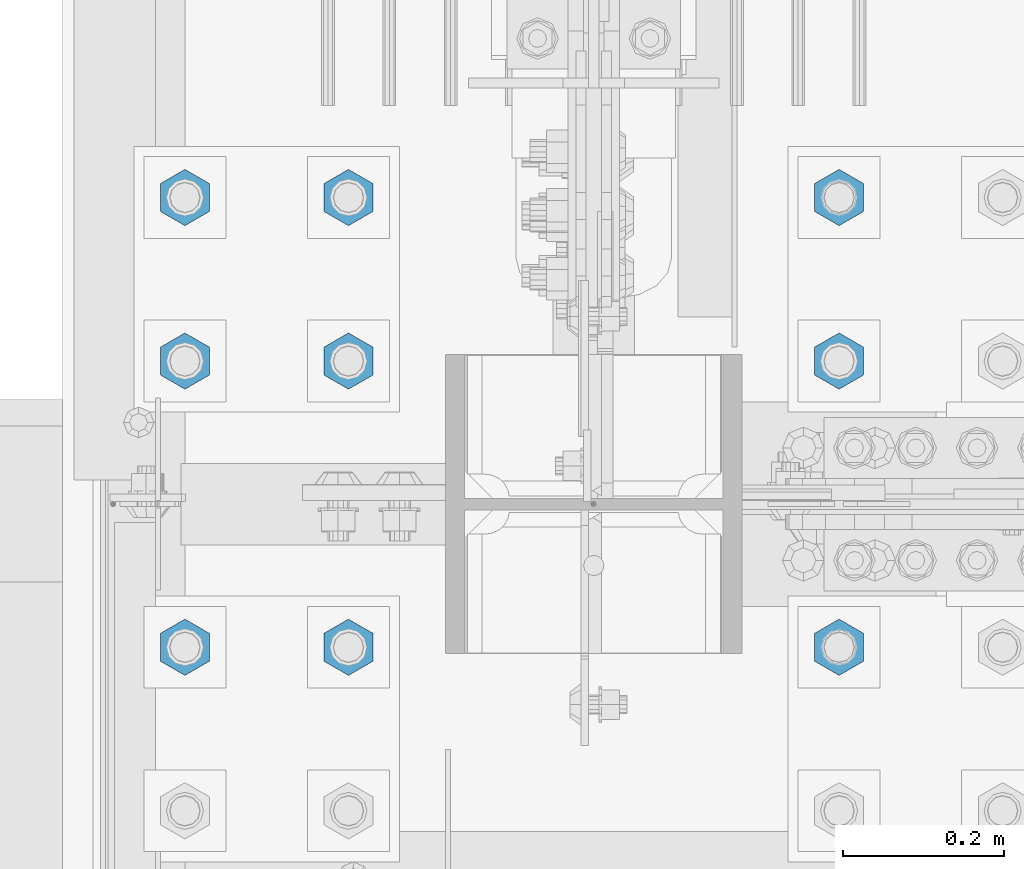
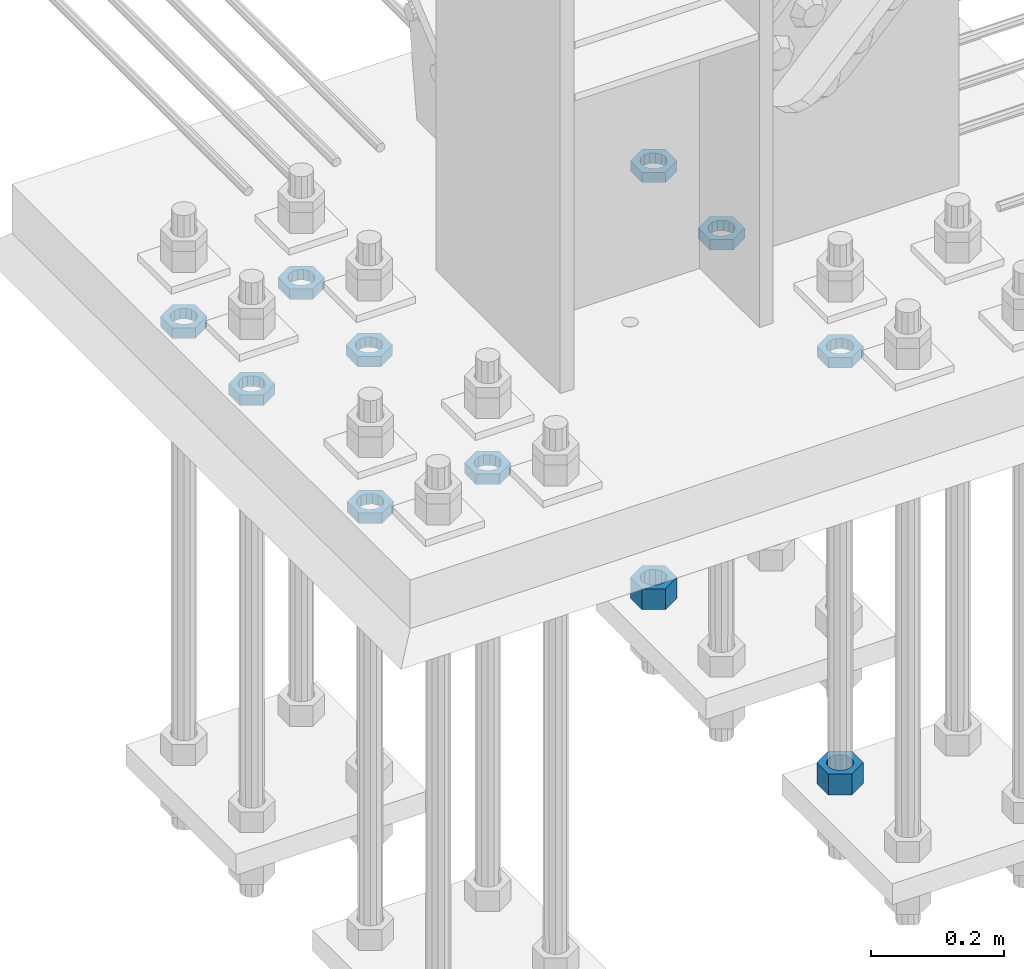
# One storey, part 2803 of 3843: 11 beams, 1 element without a shape of its own.
"""IFC2X3 building model written with IfcOpenShell, lengths in millimetres."""

from ifc_helpers import new_model, si_unit, frame, origin_with_axes, place, context, subcontext, project, spatial, faceted_brep, material, type_object, element, aggregate, save


model = new_model("IFC2X3")

# Units and contexts
model_context = context("Model", 3, precision=1e-05, world=origin_with_axes())
body_context = subcontext(model_context, "Body", "Model", "MODEL_VIEW")
ifc_project = project(units=[si_unit("LENGTHUNIT", "METRE", prefix="MILLI"), si_unit("AREAUNIT", "SQUARE_METRE"), si_unit("VOLUMEUNIT", "CUBIC_METRE"), si_unit("MASSUNIT", "GRAM", prefix="KILO"), si_unit("TIMEUNIT", "SECOND"), si_unit("PLANEANGLEUNIT", "RADIAN"), si_unit("SOLIDANGLEUNIT", "STERADIAN"), si_unit("THERMODYNAMICTEMPERATUREUNIT", "DEGREE_CELSIUS"), si_unit("LUMINOUSINTENSITYUNIT", "LUMEN")], contexts=[model_context])

# Site, building, storey
site_placement = place(None, origin_with_axes())
site = spatial("IfcSite", under=ifc_project, at=site_placement, CompositionType="ELEMENT")
building_placement = place(site_placement, origin_with_axes())
building = spatial("IfcBuilding", under=site, at=building_placement, Name="Undefined", CompositionType="ELEMENT")
storey_placement = place(building_placement, origin_with_axes())
storey = spatial("IfcBuildingStorey", under=building, at=storey_placement, Name="Undefined", CompositionType="ELEMENT", Elevation=0.0)

# Assembly, beams
assembly_placement = place(storey_placement, origin_with_axes())
assembly = element("IfcElementAssembly", 1, at=assembly_placement, inside=storey, Name="TEMPLATE", AssemblyPlace="NOTDEFINED", PredefinedType="RIGID_FRAME")
ifc_material = material(Name="STEEL/A572-50")
beam_type_1 = type_object("IfcBeamType", Name="1-1/2_HEAVY_HEX_NUT", PredefinedType="NOTDEFINED")
beam_1_placement = place(assembly_placement, frame((77317.599987793, 15379.6999969482, 29298.9000015259), z_axis=(1.0, 0.0, 0.0), x_axis=(0.0, 0.0, -1.0)))
beam_1 = element("IfcBeam", 2, at=beam_1_placement, type_object=beam_type_1, material=ifc_material, Name="NUT", ObjectType="1-1/2_HEAVY_HEX_NUT", context=body_context, shape_type="Brep", body=[
    faceted_brep([(0.0, -34.9199981689453, 0.0), (0.0, -17.4599990844727, -30.25), (38.0999999999985, -17.4599990844727, -30.25), (38.0999999999985, -34.9199981689453, 0.0), (0.0, 17.4599990844727, -30.25), (38.0999999999985, 17.4599990844727, -30.25), (0.0, 34.9199981689453, 0.0), (38.0999999999985, 34.9199981689453, 0.0), (0.0, 17.4599990844727, 30.25), (38.0999999999985, 17.4599990844727, 30.25), (0.0, -17.4599990844727, 30.25), (38.0999999999985, -17.4599990844727, 30.25), (0.0, 0.0, 20.6399993896484), (0.0, 8.9553601105581, 18.5959968835959), (38.0999999999985, 8.9553601105581, 18.5959968835959), (38.0999999999985, 0.0, 20.6399993896484), (0.0, 16.1370013209525, 12.8688291298167), (38.0999999999985, 16.1370013209525, 12.8688291298167), (0.0, 20.1225115123816, 4.59283194104501), (38.0999999999985, 20.1225115123816, 4.59283194104501), (0.0, 20.1225115123816, -4.59283194104501), (38.0999999999985, 20.1225115123816, -4.59283194104501), (0.0, 16.1370013209525, -12.8688291298167), (38.0999999999985, 16.1370013209525, -12.8688291298167), (0.0, 8.9553601105581, -18.5959968835959), (38.0999999999985, 8.9553601105581, -18.5959968835959), (0.0, 0.0, -20.6399993896484), (38.0999999999985, 0.0, -20.6399993896484), (0.0, -8.9553601105581, -18.5959968835959), (38.0999999999985, -8.9553601105581, -18.5959968835959), (0.0, -16.1370013209525, -12.8688291298167), (38.0999999999985, -16.1370013209525, -12.8688291298167), (0.0, -20.1225115123816, -4.59283194104501), (38.0999999999985, -20.1225115123816, -4.59283194104501), (0.0, -20.1225115123816, 4.59283194104501), (38.0999999999985, -20.1225115123816, 4.59283194104501), (0.0, -16.1370013209525, 12.8688291298167), (38.0999999999985, -16.1370013209525, 12.8688291298167), (0.0, -8.9553601105581, 18.5959968835959), (38.0999999999985, -8.9553601105581, 18.5959968835959)], [[[0, 1, 2, 3]], [[1, 4, 5, 2]], [[4, 6, 7, 5]], [[6, 8, 9, 7]], [[8, 10, 11, 9]], [[10, 0, 3, 11]], [[12, 13, 14, 15]], [[13, 16, 17, 14]], [[16, 18, 19, 17]], [[18, 20, 21, 19]], [[20, 22, 23, 21]], [[22, 24, 25, 23]], [[24, 26, 27, 25]], [[26, 28, 29, 27]], [[28, 30, 31, 29]], [[30, 32, 33, 31]], [[32, 34, 35, 33]], [[34, 36, 37, 35]], [[36, 38, 39, 37]], [[38, 12, 15, 39]], [[5, 7, 9, 11, 3, 2], [17, 19, 21, 23, 25, 27, 29, 31, 33, 35, 37, 39, 15, 14]], [[10, 8, 6, 4, 1, 0], [38, 36, 34, 32, 30, 28, 26, 24, 22, 20, 18, 16, 13, 12]]]),
])
beam_2_placement = place(assembly_placement, frame((77317.599987793, 14820.8999969482, 29298.9000015259), z_axis=(1.0, 0.0, 0.0), x_axis=(0.0, 0.0, -1.0)))
beam_2 = element("IfcBeam", 3, at=beam_2_placement, type_object=beam_type_1, material=ifc_material, Name="NUT", ObjectType="1-1/2_HEAVY_HEX_NUT", context=body_context, shape_type="Brep", body=[
    faceted_brep([(0.0, -34.9199981689453, 0.0), (0.0, -17.4599990844727, -30.25), (38.0999999999985, -17.4599990844727, -30.25), (38.0999999999985, -34.9199981689453, 0.0), (0.0, 17.4599990844727, -30.25), (38.0999999999985, 17.4599990844727, -30.25), (0.0, 34.9199981689453, 0.0), (38.0999999999985, 34.9199981689453, 0.0), (0.0, 17.4599990844727, 30.25), (38.0999999999985, 17.4599990844727, 30.25), (0.0, -17.4599990844727, 30.25), (38.0999999999985, -17.4599990844727, 30.25), (0.0, 0.0, 20.6399993896484), (0.0, 8.9553601105581, 18.5959968835959), (38.0999999999985, 8.9553601105581, 18.5959968835959), (38.0999999999985, 0.0, 20.6399993896484), (0.0, 16.1370013209525, 12.8688291298167), (38.0999999999985, 16.1370013209525, 12.8688291298167), (0.0, 20.1225115123816, 4.59283194104501), (38.0999999999985, 20.1225115123816, 4.59283194104501), (0.0, 20.1225115123816, -4.59283194104501), (38.0999999999985, 20.1225115123816, -4.59283194104501), (0.0, 16.1370013209525, -12.8688291298167), (38.0999999999985, 16.1370013209525, -12.8688291298167), (0.0, 8.9553601105581, -18.5959968835959), (38.0999999999985, 8.9553601105581, -18.5959968835959), (0.0, 0.0, -20.6399993896484), (38.0999999999985, 0.0, -20.6399993896484), (0.0, -8.9553601105581, -18.5959968835959), (38.0999999999985, -8.9553601105581, -18.5959968835959), (0.0, -16.1370013209525, -12.8688291298167), (38.0999999999985, -16.1370013209525, -12.8688291298167), (0.0, -20.1225115123816, -4.59283194104501), (38.0999999999985, -20.1225115123816, -4.59283194104501), (0.0, -20.1225115123816, 4.59283194104501), (38.0999999999985, -20.1225115123816, 4.59283194104501), (0.0, -16.1370013209525, 12.8688291298167), (38.0999999999985, -16.1370013209525, 12.8688291298167), (0.0, -8.9553601105581, 18.5959968835959), (38.0999999999985, -8.9553601105581, 18.5959968835959)], [[[0, 1, 2, 3]], [[1, 4, 5, 2]], [[4, 6, 7, 5]], [[6, 8, 9, 7]], [[8, 10, 11, 9]], [[10, 0, 3, 11]], [[12, 13, 14, 15]], [[13, 16, 17, 14]], [[16, 18, 19, 17]], [[18, 20, 21, 19]], [[20, 22, 23, 21]], [[22, 24, 25, 23]], [[24, 26, 27, 25]], [[26, 28, 29, 27]], [[28, 30, 31, 29]], [[30, 32, 33, 31]], [[32, 34, 35, 33]], [[34, 36, 37, 35]], [[36, 38, 39, 37]], [[38, 12, 15, 39]], [[5, 7, 9, 11, 3, 2], [17, 19, 21, 23, 25, 27, 29, 31, 33, 35, 37, 39, 15, 14]], [[10, 8, 6, 4, 1, 0], [38, 36, 34, 32, 30, 28, 26, 24, 22, 20, 18, 16, 13, 12]]]),
])
beam_type_2 = type_object("IfcBeamType", Name="1-1/2_HALF_NUT", PredefinedType="NOTDEFINED")
beam_3_placement = place(assembly_placement, frame((77317.600012207, 15176.5000030518, 30060.9), z_axis=(-1.0, 0.0, 0.0), x_axis=(0.0, 0.0, -1.0)))
beam_3 = element("IfcBeam", 4, at=beam_3_placement, type_object=beam_type_2, material=ifc_material, Name="NUT", ObjectType="1-1/2_HALF_NUT", context=body_context, shape_type="Brep", body=[
    faceted_brep([(0.0, -34.9199981689453, 0.0), (0.0, -17.4599990844727, -30.25), (19.0500000000029, -17.4599990844727, -30.25), (19.0500000000029, -34.9199981689453, 0.0), (0.0, 17.4599990844727, -30.25), (19.0500000000029, 17.4599990844727, -30.25), (0.0, 34.9199981689453, 0.0), (19.0500000000029, 34.9199981689453, 0.0), (0.0, 17.4599990844727, 30.25), (19.0500000000029, 17.4599990844727, 30.25), (0.0, -17.4599990844727, 30.25), (19.0500000000029, -17.4599990844727, 30.25), (0.0, 0.0, 20.6399993896484), (0.0, 8.9553601105581, 18.5959968835959), (19.0500000000029, 8.95536011056538, 18.5959968835959), (19.0500000000029, 0.0, 20.6399993896484), (0.0, 16.1370013209525, 12.8688291298167), (19.0500000000029, 16.1370013209489, 12.8688291298167), (0.0, 20.1225115123816, 4.59283194104501), (19.0500000000029, 20.1225115123852, 4.59283194104501), (0.0, 20.1225115123816, -4.59283194104501), (19.0500000000029, 20.1225115123852, -4.59283194104501), (0.0, 16.1370013209525, -12.8688291298167), (19.0500000000029, 16.1370013209489, -12.8688291298167), (0.0, 8.9553601105581, -18.5959968835959), (19.0500000000029, 8.95536011056538, -18.5959968835959), (0.0, 0.0, -20.6399993896484), (19.0500000000029, 0.0, -20.6399993896484), (0.0, -8.9553601105581, -18.5959968835959), (19.0500000000029, -8.95536011056538, -18.5959968835959), (0.0, -16.1370013209525, -12.8688291298167), (19.0500000000029, -16.1370013209489, -12.8688291298167), (0.0, -20.1225115123816, -4.59283194104501), (19.0500000000029, -20.1225115123852, -4.59283194104501), (0.0, -20.1225115123816, 4.59283194104501), (19.0500000000029, -20.1225115123852, 4.59283194104501), (0.0, -16.1370013209525, 12.8688291298167), (19.0500000000029, -16.1370013209489, 12.8688291298167), (0.0, -8.9553601105581, 18.5959968835959), (19.0500000000029, -8.95536011056538, 18.5959968835959)], [[[0, 1, 2, 3]], [[1, 4, 5, 2]], [[4, 6, 7, 5]], [[6, 8, 9, 7]], [[8, 10, 11, 9]], [[10, 0, 3, 11]], [[12, 13, 14, 15]], [[13, 16, 17, 14]], [[16, 18, 19, 17]], [[18, 20, 21, 19]], [[20, 22, 23, 21]], [[22, 24, 25, 23]], [[24, 26, 27, 25]], [[26, 28, 29, 27]], [[28, 30, 31, 29]], [[30, 32, 33, 31]], [[32, 34, 35, 33]], [[34, 36, 37, 35]], [[36, 38, 39, 37]], [[38, 12, 15, 39]], [[5, 7, 9, 11, 3, 2], [17, 19, 21, 23, 25, 27, 29, 31, 33, 35, 37, 39, 15, 14]], [[10, 8, 6, 4, 1, 0], [38, 36, 34, 32, 30, 28, 26, 24, 22, 20, 18, 16, 13, 12]]]),
])
beam_4_placement = place(assembly_placement, frame((77317.600012207, 15379.7000030518, 30060.9), z_axis=(-1.0, 0.0, 0.0), x_axis=(0.0, 0.0, -1.0)))
beam_4 = element("IfcBeam", 5, at=beam_4_placement, type_object=beam_type_2, material=ifc_material, Name="NUT", ObjectType="1-1/2_HALF_NUT", context=body_context, shape_type="Brep", body=[
    faceted_brep([(0.0, -34.9199981689453, 0.0), (0.0, -17.4599990844727, -30.25), (19.0500000000029, -17.4599990844727, -30.25), (19.0500000000029, -34.9199981689453, 0.0), (0.0, 17.4599990844727, -30.25), (19.0500000000029, 17.4599990844727, -30.25), (0.0, 34.9199981689453, 0.0), (19.0500000000029, 34.9199981689453, 0.0), (0.0, 17.4599990844727, 30.25), (19.0500000000029, 17.4599990844727, 30.25), (0.0, -17.4599990844727, 30.25), (19.0500000000029, -17.4599990844727, 30.25), (0.0, 0.0, 20.6399993896484), (0.0, 8.9553601105581, 18.5959968835959), (19.0500000000029, 8.95536011056538, 18.5959968835959), (19.0500000000029, 0.0, 20.6399993896484), (0.0, 16.1370013209525, 12.8688291298167), (19.0500000000029, 16.1370013209489, 12.8688291298167), (0.0, 20.1225115123816, 4.59283194104501), (19.0500000000029, 20.1225115123852, 4.59283194104501), (0.0, 20.1225115123816, -4.59283194104501), (19.0500000000029, 20.1225115123852, -4.59283194104501), (0.0, 16.1370013209525, -12.8688291298167), (19.0500000000029, 16.1370013209489, -12.8688291298167), (0.0, 8.9553601105581, -18.5959968835959), (19.0500000000029, 8.95536011056538, -18.5959968835959), (0.0, 0.0, -20.6399993896484), (19.0500000000029, 0.0, -20.6399993896484), (0.0, -8.9553601105581, -18.5959968835959), (19.0500000000029, -8.95536011056538, -18.5959968835959), (0.0, -16.1370013209525, -12.8688291298167), (19.0500000000029, -16.1370013209489, -12.8688291298167), (0.0, -20.1225115123816, -4.59283194104501), (19.0500000000029, -20.1225115123852, -4.59283194104501), (0.0, -20.1225115123816, 4.59283194104501), (19.0500000000029, -20.1225115123852, 4.59283194104501), (0.0, -16.1370013209525, 12.8688291298167), (19.0500000000029, -16.1370013209489, 12.8688291298167), (0.0, -8.9553601105581, 18.5959968835959), (19.0500000000029, -8.95536011056538, 18.5959968835959)], [[[0, 1, 2, 3]], [[1, 4, 5, 2]], [[4, 6, 7, 5]], [[6, 8, 9, 7]], [[8, 10, 11, 9]], [[10, 0, 3, 11]], [[12, 13, 14, 15]], [[13, 16, 17, 14]], [[16, 18, 19, 17]], [[18, 20, 21, 19]], [[20, 22, 23, 21]], [[22, 24, 25, 23]], [[24, 26, 27, 25]], [[26, 28, 29, 27]], [[28, 30, 31, 29]], [[30, 32, 33, 31]], [[32, 34, 35, 33]], [[34, 36, 37, 35]], [[36, 38, 39, 37]], [[38, 12, 15, 39]], [[5, 7, 9, 11, 3, 2], [17, 19, 21, 23, 25, 27, 29, 31, 33, 35, 37, 39, 15, 14]], [[10, 8, 6, 4, 1, 0], [38, 36, 34, 32, 30, 28, 26, 24, 22, 20, 18, 16, 13, 12]]]),
])
beam_5_placement = place(assembly_placement, frame((77317.599987793, 14820.8999969482, 30060.9), z_axis=(1.0, 0.0, 0.0), x_axis=(0.0, 0.0, -1.0)))
beam_5 = element("IfcBeam", 6, at=beam_5_placement, type_object=beam_type_2, material=ifc_material, Name="NUT", ObjectType="1-1/2_HALF_NUT", context=body_context, shape_type="Brep", body=[
    faceted_brep([(0.0, -34.9199981689453, 0.0), (0.0, -17.4599990844727, -30.25), (19.0500000000029, -17.4599990844727, -30.25), (19.0500000000029, -34.9199981689453, 0.0), (0.0, 17.4599990844727, -30.25), (19.0500000000029, 17.4599990844727, -30.25), (0.0, 34.9199981689453, 0.0), (19.0500000000029, 34.9199981689453, 0.0), (0.0, 17.4599990844727, 30.25), (19.0500000000029, 17.4599990844727, 30.25), (0.0, -17.4599990844727, 30.25), (19.0500000000029, -17.4599990844727, 30.25), (0.0, 0.0, 20.6399993896484), (0.0, 8.9553601105581, 18.5959968835959), (19.0500000000029, 8.95536011056538, 18.5959968835959), (19.0500000000029, 0.0, 20.6399993896484), (0.0, 16.1370013209525, 12.8688291298167), (19.0500000000029, 16.1370013209489, 12.8688291298167), (0.0, 20.1225115123816, 4.59283194104501), (19.0500000000029, 20.1225115123852, 4.59283194104501), (0.0, 20.1225115123816, -4.59283194104501), (19.0500000000029, 20.1225115123852, -4.59283194104501), (0.0, 16.1370013209525, -12.8688291298167), (19.0500000000029, 16.1370013209489, -12.8688291298167), (0.0, 8.9553601105581, -18.5959968835959), (19.0500000000029, 8.95536011056538, -18.5959968835959), (0.0, 0.0, -20.6399993896484), (19.0500000000029, 0.0, -20.6399993896484), (0.0, -8.9553601105581, -18.5959968835959), (19.0500000000029, -8.95536011056538, -18.5959968835959), (0.0, -16.1370013209525, -12.8688291298167), (19.0500000000029, -16.1370013209489, -12.8688291298167), (0.0, -20.1225115123816, -4.59283194104501), (19.0500000000029, -20.1225115123852, -4.59283194104501), (0.0, -20.1225115123816, 4.59283194104501), (19.0500000000029, -20.1225115123852, 4.59283194104501), (0.0, -16.1370013209525, 12.8688291298167), (19.0500000000029, -16.1370013209489, 12.8688291298167), (0.0, -8.9553601105581, 18.5959968835959), (19.0500000000029, -8.95536011056538, 18.5959968835959)], [[[0, 1, 2, 3]], [[1, 4, 5, 2]], [[4, 6, 7, 5]], [[6, 8, 9, 7]], [[8, 10, 11, 9]], [[10, 0, 3, 11]], [[12, 13, 14, 15]], [[13, 16, 17, 14]], [[16, 18, 19, 17]], [[18, 20, 21, 19]], [[20, 22, 23, 21]], [[22, 24, 25, 23]], [[24, 26, 27, 25]], [[26, 28, 29, 27]], [[28, 30, 31, 29]], [[30, 32, 33, 31]], [[32, 34, 35, 33]], [[34, 36, 37, 35]], [[36, 38, 39, 37]], [[38, 12, 15, 39]], [[5, 7, 9, 11, 3, 2], [17, 19, 21, 23, 25, 27, 29, 31, 33, 35, 37, 39, 15, 14]], [[10, 8, 6, 4, 1, 0], [38, 36, 34, 32, 30, 28, 26, 24, 22, 20, 18, 16, 13, 12]]]),
])
beam_6_placement = place(assembly_placement, frame((76504.800012207, 15379.7000030518, 30060.9), z_axis=(-1.0, 0.0, 0.0), x_axis=(0.0, 0.0, -1.0)))
beam_6 = element("IfcBeam", 7, at=beam_6_placement, type_object=beam_type_2, material=ifc_material, Name="NUT", ObjectType="1-1/2_HALF_NUT", context=body_context, shape_type="Brep", body=[
    faceted_brep([(0.0, -34.9199981689453, 0.0), (0.0, -17.4599990844727, -30.25), (19.0500000000029, -17.4599990844727, -30.25), (19.0500000000029, -34.9199981689453, 0.0), (0.0, 17.4599990844727, -30.25), (19.0500000000029, 17.4599990844727, -30.25), (0.0, 34.9199981689453, 0.0), (19.0500000000029, 34.9199981689453, 0.0), (0.0, 17.4599990844727, 30.25), (19.0500000000029, 17.4599990844727, 30.25), (0.0, -17.4599990844727, 30.25), (19.0500000000029, -17.4599990844727, 30.25), (0.0, 0.0, 20.6399993896484), (0.0, 8.9553601105581, 18.5959968835959), (19.0500000000029, 8.95536011056538, 18.5959968835959), (19.0500000000029, 0.0, 20.6399993896484), (0.0, 16.1370013209525, 12.8688291298167), (19.0500000000029, 16.1370013209489, 12.8688291298167), (0.0, 20.1225115123816, 4.59283194104501), (19.0500000000029, 20.1225115123852, 4.59283194104501), (0.0, 20.1225115123816, -4.59283194104501), (19.0500000000029, 20.1225115123852, -4.59283194104501), (0.0, 16.1370013209525, -12.8688291298167), (19.0500000000029, 16.1370013209489, -12.8688291298167), (0.0, 8.9553601105581, -18.5959968835959), (19.0500000000029, 8.95536011056538, -18.5959968835959), (0.0, 0.0, -20.6399993896484), (19.0500000000029, 0.0, -20.6399993896484), (0.0, -8.9553601105581, -18.5959968835959), (19.0500000000029, -8.95536011056538, -18.5959968835959), (0.0, -16.1370013209525, -12.8688291298167), (19.0500000000029, -16.1370013209489, -12.8688291298167), (0.0, -20.1225115123816, -4.59283194104501), (19.0500000000029, -20.1225115123852, -4.59283194104501), (0.0, -20.1225115123816, 4.59283194104501), (19.0500000000029, -20.1225115123852, 4.59283194104501), (0.0, -16.1370013209525, 12.8688291298167), (19.0500000000029, -16.1370013209489, 12.8688291298167), (0.0, -8.9553601105581, 18.5959968835959), (19.0500000000029, -8.95536011056538, 18.5959968835959)], [[[0, 1, 2, 3]], [[1, 4, 5, 2]], [[4, 6, 7, 5]], [[6, 8, 9, 7]], [[8, 10, 11, 9]], [[10, 0, 3, 11]], [[12, 13, 14, 15]], [[13, 16, 17, 14]], [[16, 18, 19, 17]], [[18, 20, 21, 19]], [[20, 22, 23, 21]], [[22, 24, 25, 23]], [[24, 26, 27, 25]], [[26, 28, 29, 27]], [[28, 30, 31, 29]], [[30, 32, 33, 31]], [[32, 34, 35, 33]], [[34, 36, 37, 35]], [[36, 38, 39, 37]], [[38, 12, 15, 39]], [[5, 7, 9, 11, 3, 2], [17, 19, 21, 23, 25, 27, 29, 31, 33, 35, 37, 39, 15, 14]], [[10, 8, 6, 4, 1, 0], [38, 36, 34, 32, 30, 28, 26, 24, 22, 20, 18, 16, 13, 12]]]),
])
beam_7_placement = place(assembly_placement, frame((76504.800012207, 15176.5000030518, 30060.9), z_axis=(-1.0, 0.0, 0.0), x_axis=(0.0, 0.0, -1.0)))
beam_7 = element("IfcBeam", 8, at=beam_7_placement, type_object=beam_type_2, material=ifc_material, Name="NUT", ObjectType="1-1/2_HALF_NUT", context=body_context, shape_type="Brep", body=[
    faceted_brep([(0.0, -34.9199981689453, 0.0), (0.0, -17.4599990844727, -30.25), (19.0500000000029, -17.4599990844727, -30.25), (19.0500000000029, -34.9199981689453, 0.0), (0.0, 17.4599990844727, -30.25), (19.0500000000029, 17.4599990844727, -30.25), (0.0, 34.9199981689453, 0.0), (19.0500000000029, 34.9199981689453, 0.0), (0.0, 17.4599990844727, 30.25), (19.0500000000029, 17.4599990844727, 30.25), (0.0, -17.4599990844727, 30.25), (19.0500000000029, -17.4599990844727, 30.25), (0.0, 0.0, 20.6399993896484), (0.0, 8.9553601105581, 18.5959968835959), (19.0500000000029, 8.95536011056538, 18.5959968835959), (19.0500000000029, 0.0, 20.6399993896484), (0.0, 16.1370013209525, 12.8688291298167), (19.0500000000029, 16.1370013209489, 12.8688291298167), (0.0, 20.1225115123816, 4.59283194104501), (19.0500000000029, 20.1225115123852, 4.59283194104501), (0.0, 20.1225115123816, -4.59283194104501), (19.0500000000029, 20.1225115123852, -4.59283194104501), (0.0, 16.1370013209525, -12.8688291298167), (19.0500000000029, 16.1370013209489, -12.8688291298167), (0.0, 8.9553601105581, -18.5959968835959), (19.0500000000029, 8.95536011056538, -18.5959968835959), (0.0, 0.0, -20.6399993896484), (19.0500000000029, 0.0, -20.6399993896484), (0.0, -8.9553601105581, -18.5959968835959), (19.0500000000029, -8.95536011056538, -18.5959968835959), (0.0, -16.1370013209525, -12.8688291298167), (19.0500000000029, -16.1370013209489, -12.8688291298167), (0.0, -20.1225115123816, -4.59283194104501), (19.0500000000029, -20.1225115123852, -4.59283194104501), (0.0, -20.1225115123816, 4.59283194104501), (19.0500000000029, -20.1225115123852, 4.59283194104501), (0.0, -16.1370013209525, 12.8688291298167), (19.0500000000029, -16.1370013209489, 12.8688291298167), (0.0, -8.9553601105581, 18.5959968835959), (19.0500000000029, -8.95536011056538, 18.5959968835959)], [[[0, 1, 2, 3]], [[1, 4, 5, 2]], [[4, 6, 7, 5]], [[6, 8, 9, 7]], [[8, 10, 11, 9]], [[10, 0, 3, 11]], [[12, 13, 14, 15]], [[13, 16, 17, 14]], [[16, 18, 19, 17]], [[18, 20, 21, 19]], [[20, 22, 23, 21]], [[22, 24, 25, 23]], [[24, 26, 27, 25]], [[26, 28, 29, 27]], [[28, 30, 31, 29]], [[30, 32, 33, 31]], [[32, 34, 35, 33]], [[34, 36, 37, 35]], [[36, 38, 39, 37]], [[38, 12, 15, 39]], [[5, 7, 9, 11, 3, 2], [17, 19, 21, 23, 25, 27, 29, 31, 33, 35, 37, 39, 15, 14]], [[10, 8, 6, 4, 1, 0], [38, 36, 34, 32, 30, 28, 26, 24, 22, 20, 18, 16, 13, 12]]]),
])
beam_8_placement = place(assembly_placement, frame((76708.000012207, 15379.7000030518, 30060.9), z_axis=(-1.0, 0.0, 0.0), x_axis=(0.0, 0.0, -1.0)))
beam_8 = element("IfcBeam", 9, at=beam_8_placement, type_object=beam_type_2, material=ifc_material, Name="NUT", ObjectType="1-1/2_HALF_NUT", context=body_context, shape_type="Brep", body=[
    faceted_brep([(0.0, -34.9199981689453, 0.0), (0.0, -17.4599990844727, -30.25), (19.0500000000029, -17.4599990844727, -30.25), (19.0500000000029, -34.9199981689453, 0.0), (0.0, 17.4599990844727, -30.25), (19.0500000000029, 17.4599990844727, -30.25), (0.0, 34.9199981689453, 0.0), (19.0500000000029, 34.9199981689453, 0.0), (0.0, 17.4599990844727, 30.25), (19.0500000000029, 17.4599990844727, 30.25), (0.0, -17.4599990844727, 30.25), (19.0500000000029, -17.4599990844727, 30.25), (0.0, 0.0, 20.6399993896484), (0.0, 8.9553601105581, 18.5959968835959), (19.0500000000029, 8.95536011056538, 18.5959968835959), (19.0500000000029, 0.0, 20.6399993896484), (0.0, 16.1370013209525, 12.8688291298167), (19.0500000000029, 16.1370013209489, 12.8688291298167), (0.0, 20.1225115123816, 4.59283194104501), (19.0500000000029, 20.1225115123852, 4.59283194104501), (0.0, 20.1225115123816, -4.59283194104501), (19.0500000000029, 20.1225115123852, -4.59283194104501), (0.0, 16.1370013209525, -12.8688291298167), (19.0500000000029, 16.1370013209489, -12.8688291298167), (0.0, 8.9553601105581, -18.5959968835959), (19.0500000000029, 8.95536011056538, -18.5959968835959), (0.0, 0.0, -20.6399993896484), (19.0500000000029, 0.0, -20.6399993896484), (0.0, -8.9553601105581, -18.5959968835959), (19.0500000000029, -8.95536011056538, -18.5959968835959), (0.0, -16.1370013209525, -12.8688291298167), (19.0500000000029, -16.1370013209489, -12.8688291298167), (0.0, -20.1225115123816, -4.59283194104501), (19.0500000000029, -20.1225115123852, -4.59283194104501), (0.0, -20.1225115123816, 4.59283194104501), (19.0500000000029, -20.1225115123852, 4.59283194104501), (0.0, -16.1370013209525, 12.8688291298167), (19.0500000000029, -16.1370013209489, 12.8688291298167), (0.0, -8.9553601105581, 18.5959968835959), (19.0500000000029, -8.95536011056538, 18.5959968835959)], [[[0, 1, 2, 3]], [[1, 4, 5, 2]], [[4, 6, 7, 5]], [[6, 8, 9, 7]], [[8, 10, 11, 9]], [[10, 0, 3, 11]], [[12, 13, 14, 15]], [[13, 16, 17, 14]], [[16, 18, 19, 17]], [[18, 20, 21, 19]], [[20, 22, 23, 21]], [[22, 24, 25, 23]], [[24, 26, 27, 25]], [[26, 28, 29, 27]], [[28, 30, 31, 29]], [[30, 32, 33, 31]], [[32, 34, 35, 33]], [[34, 36, 37, 35]], [[36, 38, 39, 37]], [[38, 12, 15, 39]], [[5, 7, 9, 11, 3, 2], [17, 19, 21, 23, 25, 27, 29, 31, 33, 35, 37, 39, 15, 14]], [[10, 8, 6, 4, 1, 0], [38, 36, 34, 32, 30, 28, 26, 24, 22, 20, 18, 16, 13, 12]]]),
])
beam_9_placement = place(assembly_placement, frame((76708.000012207, 15176.5000030518, 30060.9), z_axis=(-1.0, 0.0, 0.0), x_axis=(0.0, 0.0, -1.0)))
beam_9 = element("IfcBeam", 10, at=beam_9_placement, type_object=beam_type_2, material=ifc_material, Name="NUT", ObjectType="1-1/2_HALF_NUT", context=body_context, shape_type="Brep", body=[
    faceted_brep([(0.0, -34.9199981689453, 0.0), (0.0, -17.4599990844727, -30.25), (19.0500000000029, -17.4599990844727, -30.25), (19.0500000000029, -34.9199981689453, 0.0), (0.0, 17.4599990844727, -30.25), (19.0500000000029, 17.4599990844727, -30.25), (0.0, 34.9199981689453, 0.0), (19.0500000000029, 34.9199981689453, 0.0), (0.0, 17.4599990844727, 30.25), (19.0500000000029, 17.4599990844727, 30.25), (0.0, -17.4599990844727, 30.25), (19.0500000000029, -17.4599990844727, 30.25), (0.0, 0.0, 20.6399993896484), (0.0, 8.9553601105581, 18.5959968835959), (19.0500000000029, 8.95536011056538, 18.5959968835959), (19.0500000000029, 0.0, 20.6399993896484), (0.0, 16.1370013209525, 12.8688291298167), (19.0500000000029, 16.1370013209489, 12.8688291298167), (0.0, 20.1225115123816, 4.59283194104501), (19.0500000000029, 20.1225115123852, 4.59283194104501), (0.0, 20.1225115123816, -4.59283194104501), (19.0500000000029, 20.1225115123852, -4.59283194104501), (0.0, 16.1370013209525, -12.8688291298167), (19.0500000000029, 16.1370013209489, -12.8688291298167), (0.0, 8.9553601105581, -18.5959968835959), (19.0500000000029, 8.95536011056538, -18.5959968835959), (0.0, 0.0, -20.6399993896484), (19.0500000000029, 0.0, -20.6399993896484), (0.0, -8.9553601105581, -18.5959968835959), (19.0500000000029, -8.95536011056538, -18.5959968835959), (0.0, -16.1370013209525, -12.8688291298167), (19.0500000000029, -16.1370013209489, -12.8688291298167), (0.0, -20.1225115123816, -4.59283194104501), (19.0500000000029, -20.1225115123852, -4.59283194104501), (0.0, -20.1225115123816, 4.59283194104501), (19.0500000000029, -20.1225115123852, 4.59283194104501), (0.0, -16.1370013209525, 12.8688291298167), (19.0500000000029, -16.1370013209489, 12.8688291298167), (0.0, -8.9553601105581, 18.5959968835959), (19.0500000000029, -8.95536011056538, 18.5959968835959)], [[[0, 1, 2, 3]], [[1, 4, 5, 2]], [[4, 6, 7, 5]], [[6, 8, 9, 7]], [[8, 10, 11, 9]], [[10, 0, 3, 11]], [[12, 13, 14, 15]], [[13, 16, 17, 14]], [[16, 18, 19, 17]], [[18, 20, 21, 19]], [[20, 22, 23, 21]], [[22, 24, 25, 23]], [[24, 26, 27, 25]], [[26, 28, 29, 27]], [[28, 30, 31, 29]], [[30, 32, 33, 31]], [[32, 34, 35, 33]], [[34, 36, 37, 35]], [[36, 38, 39, 37]], [[38, 12, 15, 39]], [[5, 7, 9, 11, 3, 2], [17, 19, 21, 23, 25, 27, 29, 31, 33, 35, 37, 39, 15, 14]], [[10, 8, 6, 4, 1, 0], [38, 36, 34, 32, 30, 28, 26, 24, 22, 20, 18, 16, 13, 12]]]),
])
beam_10_placement = place(assembly_placement, frame((76707.999987793, 14820.8999969482, 30060.9), z_axis=(1.0, 0.0, 0.0), x_axis=(0.0, 0.0, -1.0)))
beam_10 = element("IfcBeam", 11, at=beam_10_placement, type_object=beam_type_2, material=ifc_material, Name="NUT", ObjectType="1-1/2_HALF_NUT", context=body_context, shape_type="Brep", body=[
    faceted_brep([(0.0, -34.9199981689453, 0.0), (0.0, -17.4599990844727, -30.25), (19.0500000000029, -17.4599990844727, -30.25), (19.0500000000029, -34.9199981689453, 0.0), (0.0, 17.4599990844727, -30.25), (19.0500000000029, 17.4599990844727, -30.25), (0.0, 34.9199981689453, 0.0), (19.0500000000029, 34.9199981689453, 0.0), (0.0, 17.4599990844727, 30.25), (19.0500000000029, 17.4599990844727, 30.25), (0.0, -17.4599990844727, 30.25), (19.0500000000029, -17.4599990844727, 30.25), (0.0, 0.0, 20.6399993896484), (0.0, 8.9553601105581, 18.5959968835959), (19.0500000000029, 8.95536011056538, 18.5959968835959), (19.0500000000029, 0.0, 20.6399993896484), (0.0, 16.1370013209525, 12.8688291298167), (19.0500000000029, 16.1370013209489, 12.8688291298167), (0.0, 20.1225115123816, 4.59283194104501), (19.0500000000029, 20.1225115123852, 4.59283194104501), (0.0, 20.1225115123816, -4.59283194104501), (19.0500000000029, 20.1225115123852, -4.59283194104501), (0.0, 16.1370013209525, -12.8688291298167), (19.0500000000029, 16.1370013209489, -12.8688291298167), (0.0, 8.9553601105581, -18.5959968835959), (19.0500000000029, 8.95536011056538, -18.5959968835959), (0.0, 0.0, -20.6399993896484), (19.0500000000029, 0.0, -20.6399993896484), (0.0, -8.9553601105581, -18.5959968835959), (19.0500000000029, -8.95536011056538, -18.5959968835959), (0.0, -16.1370013209525, -12.8688291298167), (19.0500000000029, -16.1370013209489, -12.8688291298167), (0.0, -20.1225115123816, -4.59283194104501), (19.0500000000029, -20.1225115123852, -4.59283194104501), (0.0, -20.1225115123816, 4.59283194104501), (19.0500000000029, -20.1225115123852, 4.59283194104501), (0.0, -16.1370013209525, 12.8688291298167), (19.0500000000029, -16.1370013209489, 12.8688291298167), (0.0, -8.9553601105581, 18.5959968835959), (19.0500000000029, -8.95536011056538, 18.5959968835959)], [[[0, 1, 2, 3]], [[1, 4, 5, 2]], [[4, 6, 7, 5]], [[6, 8, 9, 7]], [[8, 10, 11, 9]], [[10, 0, 3, 11]], [[12, 13, 14, 15]], [[13, 16, 17, 14]], [[16, 18, 19, 17]], [[18, 20, 21, 19]], [[20, 22, 23, 21]], [[22, 24, 25, 23]], [[24, 26, 27, 25]], [[26, 28, 29, 27]], [[28, 30, 31, 29]], [[30, 32, 33, 31]], [[32, 34, 35, 33]], [[34, 36, 37, 35]], [[36, 38, 39, 37]], [[38, 12, 15, 39]], [[5, 7, 9, 11, 3, 2], [17, 19, 21, 23, 25, 27, 29, 31, 33, 35, 37, 39, 15, 14]], [[10, 8, 6, 4, 1, 0], [38, 36, 34, 32, 30, 28, 26, 24, 22, 20, 18, 16, 13, 12]]]),
])
beam_11_placement = place(assembly_placement, frame((76504.799987793, 14820.8999969482, 30060.9), z_axis=(1.0, 0.0, 0.0), x_axis=(0.0, 0.0, -1.0)))
beam_11 = element("IfcBeam", 12, at=beam_11_placement, type_object=beam_type_2, material=ifc_material, Name="NUT", ObjectType="1-1/2_HALF_NUT", context=body_context, shape_type="Brep", body=[
    faceted_brep([(0.0, -34.9199981689453, 0.0), (0.0, -17.4599990844727, -30.25), (19.0500000000029, -17.4599990844727, -30.25), (19.0500000000029, -34.9199981689453, 0.0), (0.0, 17.4599990844727, -30.25), (19.0500000000029, 17.4599990844727, -30.25), (0.0, 34.9199981689453, 0.0), (19.0500000000029, 34.9199981689453, 0.0), (0.0, 17.4599990844727, 30.25), (19.0500000000029, 17.4599990844727, 30.25), (0.0, -17.4599990844727, 30.25), (19.0500000000029, -17.4599990844727, 30.25), (0.0, 0.0, 20.6399993896484), (0.0, 8.9553601105581, 18.5959968835959), (19.0500000000029, 8.95536011056538, 18.5959968835959), (19.0500000000029, 0.0, 20.6399993896484), (0.0, 16.1370013209525, 12.8688291298167), (19.0500000000029, 16.1370013209489, 12.8688291298167), (0.0, 20.1225115123816, 4.59283194104501), (19.0500000000029, 20.1225115123852, 4.59283194104501), (0.0, 20.1225115123816, -4.59283194104501), (19.0500000000029, 20.1225115123852, -4.59283194104501), (0.0, 16.1370013209525, -12.8688291298167), (19.0500000000029, 16.1370013209489, -12.8688291298167), (0.0, 8.9553601105581, -18.5959968835959), (19.0500000000029, 8.95536011056538, -18.5959968835959), (0.0, 0.0, -20.6399993896484), (19.0500000000029, 0.0, -20.6399993896484), (0.0, -8.9553601105581, -18.5959968835959), (19.0500000000029, -8.95536011056538, -18.5959968835959), (0.0, -16.1370013209525, -12.8688291298167), (19.0500000000029, -16.1370013209489, -12.8688291298167), (0.0, -20.1225115123816, -4.59283194104501), (19.0500000000029, -20.1225115123852, -4.59283194104501), (0.0, -20.1225115123816, 4.59283194104501), (19.0500000000029, -20.1225115123852, 4.59283194104501), (0.0, -16.1370013209525, 12.8688291298167), (19.0500000000029, -16.1370013209489, 12.8688291298167), (0.0, -8.9553601105581, 18.5959968835959), (19.0500000000029, -8.95536011056538, 18.5959968835959)], [[[0, 1, 2, 3]], [[1, 4, 5, 2]], [[4, 6, 7, 5]], [[6, 8, 9, 7]], [[8, 10, 11, 9]], [[10, 0, 3, 11]], [[12, 13, 14, 15]], [[13, 16, 17, 14]], [[16, 18, 19, 17]], [[18, 20, 21, 19]], [[20, 22, 23, 21]], [[22, 24, 25, 23]], [[24, 26, 27, 25]], [[26, 28, 29, 27]], [[28, 30, 31, 29]], [[30, 32, 33, 31]], [[32, 34, 35, 33]], [[34, 36, 37, 35]], [[36, 38, 39, 37]], [[38, 12, 15, 39]], [[5, 7, 9, 11, 3, 2], [17, 19, 21, 23, 25, 27, 29, 31, 33, 35, 37, 39, 15, 14]], [[10, 8, 6, 4, 1, 0], [38, 36, 34, 32, 30, 28, 26, 24, 22, 20, 18, 16, 13, 12]]]),
])
aggregate(assembly, [beam_1, beam_2, beam_3, beam_4, beam_5, beam_6, beam_7, beam_8, beam_9, beam_10, beam_11])

save(model, "model.ifc")
